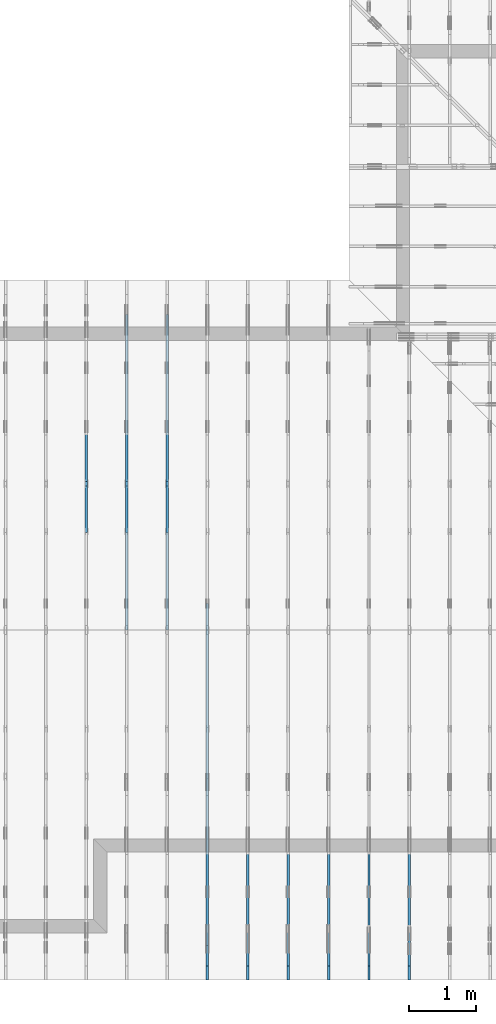
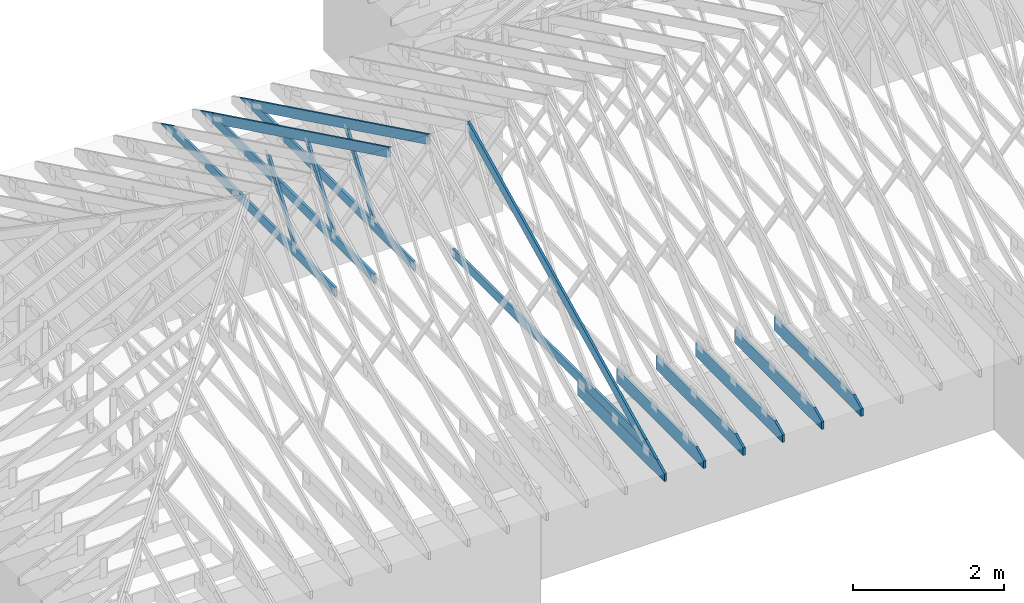
# One storey, part 11 of 159: 16 members, 9 elements without a shape of their own.
"""IFC2X3 building model written with IfcOpenShell, lengths in millimetres."""

from ifc_helpers import new_model, si_unit, frame, origin, origin_with_axes, origin_2d, place, context, project, spatial, faceted_brep, element, aggregate, save


model = new_model("IFC2X3")

# Units and contexts
model_context = context("Model", 3, precision=1e-05, world=origin())
plan_context = context("Plan", 2, precision=1e-05, world=origin_2d())
ifc_project = project(units=[si_unit("LENGTHUNIT", "METRE", prefix="MILLI"), si_unit("AREAUNIT", "SQUARE_METRE"), si_unit("VOLUMEUNIT", "CUBIC_METRE"), si_unit("SOLIDANGLEUNIT", "STERADIAN"), si_unit("PLANEANGLEUNIT", "RADIAN"), si_unit("MASSUNIT", "GRAM"), si_unit("TIMEUNIT", "SECOND"), si_unit("THERMODYNAMICTEMPERATUREUNIT", "DEGREE_CELSIUS"), si_unit("LUMINOUSINTENSITYUNIT", "LUMEN")], contexts=[model_context, plan_context])

# Site, building, storey
site_placement = place(None, origin_with_axes())
site = spatial("IfcSite", under=ifc_project, at=site_placement, CompositionType="ELEMENT")
building_placement = place(site_placement, origin_with_axes())
building = spatial("IfcBuilding", under=site, at=building_placement, Name="Plan 1", CompositionType="ELEMENT")
storey_placement = place(building_placement, origin_with_axes())
storey = spatial("IfcBuildingStorey", under=building, at=storey_placement, Name="Etasje 1", CompositionType="ELEMENT", Elevation=0.0)

# Assembly, member
assembly_1_placement = place(storey_placement, frame((10875.02226140475, -699.9989301294845, 1.1021457184401395e-15), z_axis=(-1.0, 1.836909530733566e-16, 6.123031769111886e-17), x_axis=(-1.836909530733566e-16, -1.0, 0.0)))
assembly_1 = element("IfcElementAssembly", 1, at=assembly_1_placement, inside=storey, Name="T4 (96)", AssemblyPlace="FACTORY", PredefinedType="TRUSS")
member_1_placement = place(assembly_1_placement, frame((-2299.9990234375, 0.0, -36.0), z_axis=(0.0, 0.0, 1.0), x_axis=(1.0, 0.0, 0.0)))
member_1 = element("IfcMember", 2, at=member_1_placement, Name="T4-U14", context=model_context, shape_type="Brep", body=[
    faceted_brep([(2088.8177337646484, 223.0, 36.0), (0.0, 223.0, 36.0), (0.0, 0.0, 36.0), (2300.0000933080446, 0.0, 36.0), (2300.0000933080446, 119.99948120117188, 36.0), (0.0, 223.0, 0.0), (2088.8177337646484, 223.0, 2.5579794687450473e-13), (2300.0000933080446, 119.99948120117188, 2.816594728057092e-13), (2300.0000933080446, 0.0, 2.816594728057092e-13), (0.0, 0.0, 0.0), (2088.8177277548316, 223.00000000000023, 2.524354896707238e-29), (2088.8177277548316, 223.00000000000023, 36.0), (2300.0000933080146, 119.99947818928456, 36.0), (2300.0000933080146, 119.99947818928456, 2.524354896707238e-29), (9.330801458418136e-05, 223.0, 0.0), (9.330801458418136e-05, 223.0, 36.0), (2088.817727754831, 222.99999999999986, 36.0), (2088.817727754831, 222.99999999999986, -7.888609052210118e-30), (9.330801458418136e-05, 0.0, 0.0), (9.330801458638566e-05, -2.6993892992798474e-31, 36.0), (9.330801461369438e-05, 223.0, 36.0), (9.330801461149009e-05, 223.0, -1.6721217180559947e-30), (2300.0000933080146, -4.2248920920855827e-13, 2.5869148500909603e-29), (2300.0000933080146, -4.20284917771678e-13, 36.0), (9.330801458418136e-05, 2.204274297042151e-15, 36.0), (9.330801458418136e-05, -1.713983812835093e-20, 1.0494777337732796e-36), (2300.0000933080146, 119.99947818928416, 0.0), (2300.0000933080146, 119.99947818928416, 36.0), (2300.0000933080146, 0.0, 36.0), (2300.0000933080146, 0.0, 0.0)], [[[0, 1, 2, 3, 4]], [[5, 6, 7, 8, 9]], [[10, 11, 12, 13]], [[14, 15, 16, 17]], [[18, 19, 20, 21]], [[22, 23, 24, 25]], [[26, 27, 28, 29]]]),
])
aggregate(assembly_1, [member_1])

assembly_2_placement = place(storey_placement, frame((10275.02226140475, -699.9989301294845, 1.1021457184401395e-15), z_axis=(-1.0, 1.836909530733566e-16, 6.123031769111886e-17), x_axis=(-1.836909530733566e-16, -1.0, 0.0)))
assembly_2 = element("IfcElementAssembly", 3, at=assembly_2_placement, inside=storey, Name="T3 (95)", AssemblyPlace="FACTORY", PredefinedType="TRUSS")
member_2_placement = place(assembly_2_placement, frame((-2300.000000000002, 0.0, -36.0), z_axis=(0.0, 0.0, 1.0), x_axis=(1.0, 0.0, 0.0)))
member_2 = element("IfcMember", 4, at=member_2_placement, Name="T3-U14", context=model_context, shape_type="Brep", body=[
    faceted_brep([(2088.8187103271503, 223.0, 36.0), (1.8189894035458565e-12, 223.0, 36.0), (1.8189894035458565e-12, 0.0, 36.0), (2300.0, 0.0, 36.0), (2299.9999712377066, 120.00001525878906, 36.0), (1.8189894035458565e-12, 223.0, 2.227545981117832e-28), (2088.8187103271503, 223.0, 2.5579806646496917e-13), (2299.9999712377066, 120.00001525878906, 2.81659457856898e-13), (2300.0, 0.0, 2.8165946137914677e-13), (1.8189894035458565e-12, 0.0, 2.227545981117832e-28), (2088.8187043173352, 223.0000000000001, 1.262177448353619e-29), (2088.8187043173352, 223.0000000000001, 36.0), (2299.999971237707, 120.00001402830935, 36.0), (2299.999971237707, 120.00001402830935, 1.262177448353619e-29), (0.0, 223.0, 0.0), (-1.3496946496399237e-31, 223.0, 36.0), (2088.818704317335, 222.99999999999986, 36.0), (2088.818704317335, 222.99999999999986, -7.888609052210118e-30), (0.0, 0.0, 0.0), (2.204291436880279e-15, -2.6993892992798474e-31, 36.0), (2.951301312711929e-14, 223.0, 36.0), (2.7308721690239013e-14, 223.0, -1.6721217048316832e-30), (2300.0, -4.2248919206872015e-13, 2.586914745143187e-29), (2300.0, -4.202849006318399e-13, 36.0), (4.049083948919771e-31, 2.204291436880279e-15, 36.0), (0.0, 0.0, 0.0), (2299.999999999868, 120.00001402830925, 1.7611162946620003e-21), (2299.999999999868, 120.00001402830925, 36.0), (2299.999999999868, 0.0, 36.0), (2299.999999999868, 0.0, -8.077935669463161e-27)], [[[0, 1, 2, 3, 4]], [[5, 6, 7, 8, 9]], [[10, 11, 12, 13]], [[14, 15, 16, 17]], [[18, 19, 20, 21]], [[22, 23, 24, 25]], [[26, 27, 28, 29]]]),
])
aggregate(assembly_2, [member_2])

assembly_3_placement = place(storey_placement, frame((9675.022261404752, 9699.99999999999, 1.1021457184401395e-15), z_axis=(-1.0, 1.836909530733566e-16, 6.123031769111886e-17), x_axis=(-1.836909530733566e-16, -1.0, 0.0)))
assembly_3 = element("IfcElementAssembly", 5, at=assembly_3_placement, inside=storey, Name="T2 (94)", AssemblyPlace="FACTORY", PredefinedType="TRUSS")
member_3_placement = place(assembly_3_placement, frame((8099.998930129474, 0.0, -36.0), z_axis=(0.0, 0.0, 1.0), x_axis=(1.0, 0.0, 0.0)))
member_3 = element("IfcMember", 6, at=member_3_placement, Name="T2-U14", context=model_context, shape_type="Brep", body=[
    faceted_brep([(2088.8184526830264, 223.0, 36.0), (9.330802640761249e-05, 223.0, 36.0), (9.330802640761249e-05, 0.0, 36.0), (2300.0000933080264, 0.0, 36.0), (2300.0000933080264, 120.00001525878906, 36.0), (9.330802640761249e-05, 223.0, 1.1426560200138842e-20), (2088.8184526830264, 223.0, 2.557980349137061e-13), (2300.0000933080264, 120.00001525878906, 2.8165947280570696e-13), (2300.0000933080264, 0.0, 2.8165947280570696e-13), (9.330802640761249e-05, 0.0, 1.1426560200138842e-20), (2088.8187043173357, 223.00000000000034, 2.524354896707238e-29), (2088.8187043173357, 223.00000000000034, 36.0), (2299.999971237707, 120.00001402830958, 36.0), (2299.999971237707, 120.00001402830958, 2.524354896707238e-29), (0.0, 223.0, 0.0), (-1.3496946496399237e-31, 223.0, 36.0), (2088.818704317335, 222.99999999999986, 36.0), (2088.818704317335, 222.99999999999986, -7.888609052210118e-30), (0.0, 0.0, 0.0), (2.204291436880279e-15, -2.6993892992798474e-31, 36.0), (2.951301312711929e-14, 223.0, 36.0), (2.7308721690239013e-14, 223.0, -1.6721217048316832e-30), (2300.0, -4.2248919206872015e-13, 2.586914745143187e-29), (2300.0, -4.202849006318399e-13, 36.0), (4.049083948919771e-31, 2.204291436880279e-15, 36.0), (0.0, 0.0, 0.0), (2299.999999999868, 120.00001402830924, 1.7611162946620003e-21), (2299.999999999868, 120.00001402830924, 36.0), (2299.999999999868, 0.0, 36.0), (2299.999999999868, 0.0, -8.077935669463161e-27)], [[[0, 1, 2, 3, 4]], [[5, 6, 7, 8, 9]], [[10, 11, 12, 13]], [[14, 15, 16, 17]], [[18, 19, 20, 21]], [[22, 23, 24, 25]], [[26, 27, 28, 29]]]),
])
aggregate(assembly_3, [member_3])

assembly_4_placement = place(storey_placement, frame((9075.022261404752, 9699.99999999999, 1.1021457184401395e-15), z_axis=(-1.0, 1.836909530733566e-16, 6.123031769111886e-17), x_axis=(-1.836909530733566e-16, -1.0, 0.0)))
assembly_4 = element("IfcElementAssembly", 7, at=assembly_4_placement, inside=storey, Name="T2 (93)", AssemblyPlace="FACTORY", PredefinedType="TRUSS")
member_4_placement = place(assembly_4_placement, frame((8099.998930129474, 0.0, -36.0), z_axis=(0.0, 0.0, 1.0), x_axis=(1.0, 0.0, 0.0)))
member_4 = element("IfcMember", 8, at=member_4_placement, Name="T2-U14", context=model_context, shape_type="Brep", body=[
    faceted_brep([(2088.8184526830264, 223.0, 36.0), (9.330802640761249e-05, 223.0, 36.0), (9.330802640761249e-05, 0.0, 36.0), (2300.0000933080264, 0.0, 36.0), (2300.0000933080264, 120.00001525878906, 36.0), (9.330802640761249e-05, 223.0, 1.1426560200138842e-20), (2088.8184526830264, 223.0, 2.557980349137061e-13), (2300.0000933080264, 120.00001525878906, 2.8165947280570696e-13), (2300.0000933080264, 0.0, 2.8165947280570696e-13), (9.330802640761249e-05, 0.0, 1.1426560200138842e-20), (2088.8187043173357, 223.00000000000034, 2.524354896707238e-29), (2088.8187043173357, 223.00000000000034, 36.0), (2299.999971237707, 120.00001402830958, 36.0), (2299.999971237707, 120.00001402830958, 2.524354896707238e-29), (0.0, 223.0, 0.0), (-1.3496946496399237e-31, 223.0, 36.0), (2088.818704317335, 222.99999999999986, 36.0), (2088.818704317335, 222.99999999999986, -7.888609052210118e-30), (0.0, 0.0, 0.0), (2.204291436880279e-15, -2.6993892992798474e-31, 36.0), (2.951301312711929e-14, 223.0, 36.0), (2.7308721690239013e-14, 223.0, -1.6721217048316832e-30), (2300.0, -4.2248919206872015e-13, 2.586914745143187e-29), (2300.0, -4.202849006318399e-13, 36.0), (4.049083948919771e-31, 2.204291436880279e-15, 36.0), (0.0, 0.0, 0.0), (2299.999999999868, 120.00001402830924, 1.7611162946620003e-21), (2299.999999999868, 120.00001402830924, 36.0), (2299.999999999868, 0.0, 36.0), (2299.999999999868, 0.0, -8.077935669463161e-27)], [[[0, 1, 2, 3, 4]], [[5, 6, 7, 8, 9]], [[10, 11, 12, 13]], [[14, 15, 16, 17]], [[18, 19, 20, 21]], [[22, 23, 24, 25]], [[26, 27, 28, 29]]]),
])
aggregate(assembly_4, [member_4])

assembly_5_placement = place(storey_placement, frame((8475.022261404752, 9699.99999999999, 1.1021457184401395e-15), z_axis=(-1.0, 1.836909530733566e-16, 6.123031769111886e-17), x_axis=(-1.836909530733566e-16, -1.0, 0.0)))
assembly_5 = element("IfcElementAssembly", 9, at=assembly_5_placement, inside=storey, Name="T2 (92)", AssemblyPlace="FACTORY", PredefinedType="TRUSS")
member_5_placement = place(assembly_5_placement, frame((8099.998930129474, 0.0, -36.0), z_axis=(0.0, 0.0, 1.0), x_axis=(1.0, 0.0, 0.0)))
member_5 = element("IfcMember", 10, at=member_5_placement, Name="T2-U14", context=model_context, shape_type="Brep", body=[
    faceted_brep([(2088.8184526830264, 223.0, 36.0), (9.330802640761249e-05, 223.0, 36.0), (9.330802640761249e-05, 0.0, 36.0), (2300.0000933080264, 0.0, 36.0), (2300.0000933080264, 120.00001525878906, 36.0), (9.330802640761249e-05, 223.0, 1.1426560200138842e-20), (2088.8184526830264, 223.0, 2.557980349137061e-13), (2300.0000933080264, 120.00001525878906, 2.8165947280570696e-13), (2300.0000933080264, 0.0, 2.8165947280570696e-13), (9.330802640761249e-05, 0.0, 1.1426560200138842e-20), (2088.8187043173357, 223.00000000000034, 2.524354896707238e-29), (2088.8187043173357, 223.00000000000034, 36.0), (2299.999971237707, 120.00001402830958, 36.0), (2299.999971237707, 120.00001402830958, 2.524354896707238e-29), (0.0, 223.0, 0.0), (-1.3496946496399237e-31, 223.0, 36.0), (2088.818704317335, 222.99999999999986, 36.0), (2088.818704317335, 222.99999999999986, -7.888609052210118e-30), (0.0, 0.0, 0.0), (2.204291436880279e-15, -2.6993892992798474e-31, 36.0), (2.951301312711929e-14, 223.0, 36.0), (2.7308721690239013e-14, 223.0, -1.6721217048316832e-30), (2300.0, -4.2248919206872015e-13, 2.586914745143187e-29), (2300.0, -4.202849006318399e-13, 36.0), (4.049083948919771e-31, 2.204291436880279e-15, 36.0), (0.0, 0.0, 0.0), (2299.999999999868, 120.00001402830924, 1.7611162946620003e-21), (2299.999999999868, 120.00001402830924, 36.0), (2299.999999999868, 0.0, 36.0), (2299.999999999868, 0.0, -8.077935669463161e-27)], [[[0, 1, 2, 3, 4]], [[5, 6, 7, 8, 9]], [[10, 11, 12, 13]], [[14, 15, 16, 17]], [[18, 19, 20, 21]], [[22, 23, 24, 25]], [[26, 27, 28, 29]]]),
])
aggregate(assembly_5, [member_5])

# Assembly, members
assembly_6_placement = place(storey_placement, frame((7875.0222614047525, 9699.99999999999, 1.1021457184401395e-15), z_axis=(-1.0, 1.836909530733566e-16, 6.123031769111886e-17), x_axis=(-1.836909530733566e-16, -1.0, 0.0)))
assembly_6 = element("IfcElementAssembly", 11, at=assembly_6_placement, inside=storey, Name="T2 (91)", AssemblyPlace="FACTORY", PredefinedType="TRUSS")
member_6_placement = place(assembly_6_placement, frame((5135.120455399391, 2523.187516882459, -36.0), z_axis=(0.0, 0.0, 1.0), x_axis=(0.8987940462991668, -0.4383711467890778, 0.0)))
member_6 = element("IfcMember", 12, at=member_6_placement, Name="T2-O3", context=model_context, shape_type="Brep", body=[
    faceted_brep([(5212.955657516367, 148.00034936960947, 36.0), (2.9272871415741974e-05, 148.00034936960947, 36.0), (72.18443128276795, 0.00027202273031434743, 36.0), (4909.50997264878, 0.00027202273031434743, 36.0), (2.9272871415741974e-05, 148.00034936960947, 3.584774433034307e-21), (5212.955657516367, 148.00034936960947, 6.383818620388851e-13), (4909.50997264878, 0.00027202273031434743, 6.012217106660022e-13), (72.18443128276795, 0.00027202273031434743, 8.83975131959324e-15), (72.18442310739601, 0.00018235889274720307, -7.888609052210118e-31), (72.18442310739601, 0.00018235889274720307, 36.0), (2.842170943040401e-14, 148.00018235817151, 36.0), (2.842170943040401e-14, 148.00018235817151, -2.3665827156630354e-30), (4909.510346538232, 0.0001823580668906902, 2.246999438374223e-28), (4909.510346538232, 0.0001823580668928945, 36.0), (72.18442310739601, 0.00018235889269189838, 36.0), (72.18442310739601, 0.0001823588926896941, 3.303759786827862e-30), (5212.955315092269, 148.00018235821926, -2.524354896707238e-29), (5212.955315092269, 148.00018235821926, 36.0), (4909.51034653823, 0.00018235807056043996, 36.0), (4909.51034653823, 0.00018235807056043996, -2.524354896707238e-29), (0.0, 148.00018235817151, 0.0), (0.0, 148.00018235817151, 36.0), (5212.95531509227, 148.00018235821864, 36.0), (5212.95531509227, 148.00018235821867, -1.1044052673094165e-29)], [[[0, 1, 2, 3]], [[4, 5, 6, 7]], [[8, 9, 10, 11]], [[12, 13, 14, 15]], [[16, 17, 18, 19]], [[20, 21, 22, 23]]]),
])
member_7_placement = place(assembly_6_placement, frame((8099.998930129474, 0.0, -36.0), z_axis=(0.0, 0.0, 1.0), x_axis=(1.0, 0.0, 0.0)))
member_7 = element("IfcMember", 13, at=member_7_placement, Name="T2-U14", context=model_context, shape_type="Brep", body=[
    faceted_brep([(2088.8184526830264, 223.0, 36.0), (9.330802640761249e-05, 223.0, 36.0), (9.330802640761249e-05, 0.0, 36.0), (2300.0000933080264, 0.0, 36.0), (2300.0000933080264, 120.00001525878906, 36.0), (9.330802640761249e-05, 223.0, 1.1426560200138842e-20), (2088.8184526830264, 223.0, 2.557980349137061e-13), (2300.0000933080264, 120.00001525878906, 2.8165947280570696e-13), (2300.0000933080264, 0.0, 2.8165947280570696e-13), (9.330802640761249e-05, 0.0, 1.1426560200138842e-20), (2088.8187043173357, 223.00000000000034, 2.524354896707238e-29), (2088.8187043173357, 223.00000000000034, 36.0), (2299.999971237707, 120.00001402830958, 36.0), (2299.999971237707, 120.00001402830958, 2.524354896707238e-29), (0.0, 223.0, 0.0), (-1.3496946496399237e-31, 223.0, 36.0), (2088.818704317335, 222.99999999999986, 36.0), (2088.818704317335, 222.99999999999986, -7.888609052210118e-30), (0.0, 0.0, 0.0), (2.204291436880279e-15, -2.6993892992798474e-31, 36.0), (2.951301312711929e-14, 223.0, 36.0), (2.7308721690239013e-14, 223.0, -1.6721217048316832e-30), (2300.0, -4.2248919206872015e-13, 2.586914745143187e-29), (2300.0, -4.202849006318399e-13, 36.0), (4.049083948919771e-31, 2.204291436880279e-15, 36.0), (0.0, 0.0, 0.0), (2299.999999999868, 120.00001402830924, 1.7611162946620003e-21), (2299.999999999868, 120.00001402830924, 36.0), (2299.999999999868, 0.0, 36.0), (2299.999999999868, 0.0, -8.077935669463161e-27)], [[[0, 1, 2, 3, 4]], [[5, 6, 7, 8, 9]], [[10, 11, 12, 13]], [[14, 15, 16, 17]], [[18, 19, 20, 21]], [[22, 23, 24, 25]], [[26, 27, 28, 29]]]),
])
member_8_placement = place(assembly_6_placement, frame((10188.817634446803, 370.99999999999994, -36.0), z_axis=(0.0, 0.0, 1.0), x_axis=(-1.0, 1.2246063538223773e-16, 0.0)))
member_8 = element("IfcMember", 14, at=member_8_placement, Name="T2-U32", context=model_context, shape_type="Brep", body=[
    faceted_brep([(5379.999763353053, 148.0000000000006, 36.0), (0.00025163430291286204, 148.0000000000006, 36.0), (303.4445875718029, 0.0, 36.0), (5379.999763353053, 0.0, 36.0), (0.00025163430291286204, 148.0000000000006, 3.081529661867556e-20), (5379.999763353053, 148.0000000000006, 6.588381893765035e-13), (5379.999763353053, 0.0, 6.588381893765035e-13), (303.4445875718029, 0.0, 3.716001699734406e-14), (303.4449685537348, 1.2789769243681803e-13, -3.99587178143416e-30), (303.4449685537348, 1.2789769243681803e-13, 36.0), (7.105427357601002e-15, 148.00000000000009, 36.0), (7.105427357601002e-15, 148.00000000000009, -2.9555199832572376e-30), (5380.0, -8.745704898130424e-13, 6.051131012552325e-29), (5380.0, -8.723661983761621e-13, 36.0), (303.4449685537347, 6.015103367954605e-14, 36.0), (303.4449685537347, 5.794674224266577e-14, 3.4129837543094226e-30), (5380.0, 148.00000000000006, 0.0), (5380.0, 148.00000000000006, 36.0), (5380.0, 1.1368683772161603e-13, 36.0), (5380.0, 1.1368683772161603e-13, 0.0), (0.0, 148.00000000000006, 0.0), (-1.3496946496399237e-31, 148.00000000000006, 36.0), (5380.0, 147.99999999999972, 36.0), (5380.0, 147.99999999999972, -2.0510383535746307e-29)], [[[0, 1, 2, 3]], [[4, 5, 6, 7]], [[8, 9, 10, 11]], [[12, 13, 14, 15]], [[16, 17, 18, 19]], [[20, 21, 22, 23]]]),
])
aggregate(assembly_6, [member_6, member_7, member_8])

assembly_7_placement = place(storey_placement, frame((7275.0222614047525, 9699.99999999999, 1.1021457184401395e-15), z_axis=(-1.0, 1.836909530733566e-16, 6.123031769111886e-17), x_axis=(-1.836909530733566e-16, -1.0, 0.0)))
assembly_7 = element("IfcElementAssembly", 15, at=assembly_7_placement, inside=storey, Name="T2 (90)", AssemblyPlace="FACTORY", PredefinedType="TRUSS")
member_9_placement = place(assembly_7_placement, frame((579.5051980003889, 237.97847286708455, -36.00000000000001), z_axis=(0.0, 0.0, 1.0), x_axis=(0.8987940462991671, 0.43837114678907757, 0.0)))
member_9 = element("IfcMember", 16, at=member_9_placement, Name="T2-O3", context=model_context, shape_type="Brep", body=[
    faceted_brep([(5212.955369683486, 148.00001471731446, 36.0), (1.573016606926103e-05, 148.00001471731446, 36.0), (303.44498744329735, 0.0, 36.0), (5140.770967673589, 0.0, 36.0), (1.573016606926103e-05, 148.00001471731446, 1.9263261315098228e-21), (5212.955369683486, 148.00001471731446, 6.383818267906877e-13), (5140.770967673589, 0.0, 6.295420790558688e-13), (303.44498744329735, 0.0, 3.716006596586134e-14), (303.44496855236554, 9.213724169399029e-06, 8.404281481000962e-31), (303.44496855236554, 9.213724169399029e-06, 36.0), (0.0, 148.000009213056, 36.0), (0.0, 148.000009213056, -1.9992365007213114e-31), (5140.770891984262, 9.214032787493993e-06, -1.5668329852774188e-28), (5140.770891984262, 9.214032789698284e-06, 36.0), (303.4449685523656, 9.213724336859708e-06, 36.0), (303.4449685523656, 9.213724334655416e-06, -9.24856583218491e-30), (5212.955315091657, 148.00000921330889, -5.793884668474286e-29), (5212.955315091657, 148.00000921330889, 36.0), (5140.770891984262, 9.214030342263868e-06, 36.0), (5140.770891984262, 9.214030342263868e-06, -5.743143320920135e-29), (0.0, 148.000009213056, 0.0), (0.0, 148.000009213056, 36.0), (5212.955315091657, 148.00000921330917, 36.0), (5212.955315091657, 148.00000921330917, 9.466330862652142e-30)], [[[0, 1, 2, 3]], [[4, 5, 6, 7]], [[8, 9, 10, 11]], [[12, 13, 14, 15]], [[16, 17, 18, 19]], [[20, 21, 22, 23]]]),
])
member_10_placement = place(assembly_7_placement, frame((4808.81787109375, 371.0000000000005, -36.0), z_axis=(0.0, 0.0, 1.0), x_axis=(-1.0, 1.2246063538223773e-16, 0.0)))
member_10 = element("IfcMember", 17, at=member_10_placement, Name="T2-U35", context=model_context, shape_type="Brep", body=[
    faceted_brep([(4597.636581420898, 148.00000000000105, 36.0), (0.0, 148.00000000000105, 36.0), (0.0, 5.115907697472721e-13, 36.0), (4294.191589355469, 5.115907697472721e-13, 36.0), (0.0, 148.00000000000105, 0.0), (4597.636581420898, 148.00000000000105, 5.630294970174226e-13), (4294.191589355469, 5.115907697472721e-13, 5.25869430485532e-13), (0.0, 5.115907697472721e-13, 0.0), (0.00023664694708713796, 0.0, 0.0), (0.00023664694708934225, -2.6993892992798474e-31, 36.0), (0.00023664694710746643, 147.99999999999994, 36.0), (0.00023664694710526213, 147.99999999999994, -1.1097479173457682e-30), (4294.191606856883, -7.888042053292689e-13, 1.1094846280734072e-28), (4294.191606856883, -7.865999138923886e-13, 36.0), (0.00023664694708713796, 2.2041915808575547e-15, 36.0), (0.00023664694708713796, -9.985602272457245e-20, 6.114215994797155e-36), (4597.636575412006, 148.00000000000205, -2.5243548967072372e-29), (4597.636575412006, 148.00000000000205, 36.0), (4294.191606856883, 1.5916157281026244e-12, 36.0), (4294.191606856883, 1.5916157281026244e-12, -2.5243548967072372e-29), (0.00023664694708713796, 147.99999999999994, 0.0), (0.00023664694708713796, 147.99999999999994, 36.0), (4597.636575412005, 148.00000000000068, 36.0), (4597.636575412005, 148.00000000000068, -2.208810534618833e-29)], [[[0, 1, 2, 3]], [[4, 5, 6, 7]], [[8, 9, 10, 11]], [[12, 13, 14, 15]], [[16, 17, 18, 19]], [[20, 21, 22, 23]]]),
])
member_11_placement = place(assembly_7_placement, frame((2992.962039007774, 1415.1000197155186, -36.0), z_axis=(0.0, 0.0, 1.0), x_axis=(0.5642475050068997, -0.8256056886271368, 0.0)))
member_11 = element("IfcMember", 18, at=member_11_placement, Name="T2-D42", context=model_context, shape_type="Brep", body=[
    faceted_brep([(1236.1860950310158, 73.0001983605489, 36.0), (10.714657585100667, 73.0001983605489, 36.0), (2.9073682981106685e-06, 0.00014238622361517628, 36.0), (1264.647317839714, 0.00014238622361517628, 36.0), (10.714657585100667, 73.0001983605489, 1.3121237757745405e-15), (1236.1860950310158, 73.0001983605489, 1.513841346481855e-13), (1264.647317839714, 0.00014238622361517628, 1.5486951407709413e-13), (2.9073682981106685e-06, 0.00014238622361517628, 3.560381690768076e-22), (-1.0876495965808294e-15, 9.815680186891362e-05, 6.73106873190455e-32), (1.0932755894164925e-15, 9.815680186859351e-05, 36.0), (10.71468588481117, 73.00009815680141, 36.0), (10.714685884811168, 73.00009815680141, -5.004528960490232e-31), (1264.6473849234712, 9.81568027596822e-05, 5.682548008281813e-29), (1264.6473849234712, 9.815680276188649e-05, 36.0), (-1.5529013882837331e-30, 9.815680187095826e-05, 36.0), (0.0, 9.815680186875397e-05, 0.0), (1236.1860298813824, 73.00009815680414, 0.0), (1236.1860298813824, 73.00009815680414, 36.0), (1264.6473849234712, 9.81568037445868e-05, 36.0), (1264.6473849234712, 9.81568037445868e-05, 1.262177448353619e-29), (10.714685884811162, 73.00009815680141, 0.0), (10.714685884811162, 73.0000981568014, 36.0), (1236.1860298813824, 73.00009815680406, 36.0), (1236.1860298813824, 73.00009815680406, -5.5220263365470826e-30)], [[[0, 1, 2, 3]], [[4, 5, 6, 7]], [[8, 9, 10, 11]], [[12, 13, 14, 15]], [[16, 17, 18, 19]], [[20, 21, 22, 23]]]),
])
aggregate(assembly_7, [member_9, member_10, member_11])

assembly_8_placement = place(storey_placement, frame((6675.0222614047525, 9699.99999999999, 1.1021457184401395e-15), z_axis=(-1.0, 1.836909530733566e-16, 6.123031769111886e-17), x_axis=(-1.836909530733566e-16, -1.0, 0.0)))
assembly_8 = element("IfcElementAssembly", 19, at=assembly_8_placement, inside=storey, Name="T2 (89)", AssemblyPlace="FACTORY", PredefinedType="TRUSS")
member_12_placement = place(assembly_8_placement, frame((579.5051980003889, 237.97847286708455, -36.00000000000001), z_axis=(0.0, 0.0, 1.0), x_axis=(0.8987940462991671, 0.43837114678907757, 0.0)))
member_12 = element("IfcMember", 20, at=member_12_placement, Name="T2-O3", context=model_context, shape_type="Brep", body=[
    faceted_brep([(5212.955369683486, 148.00001471731446, 36.0), (1.573016606926103e-05, 148.00001471731446, 36.0), (303.44498744329735, 0.0, 36.0), (5140.770967673589, 0.0, 36.0), (1.573016606926103e-05, 148.00001471731446, 1.9263261315098228e-21), (5212.955369683486, 148.00001471731446, 6.383818267906877e-13), (5140.770967673589, 0.0, 6.295420790558688e-13), (303.44498744329735, 0.0, 3.716006596586134e-14), (303.44496855236554, 9.213724169399029e-06, 8.404281481000962e-31), (303.44496855236554, 9.213724169399029e-06, 36.0), (0.0, 148.000009213056, 36.0), (0.0, 148.000009213056, -1.9992365007213114e-31), (5140.770891984262, 9.214032787493993e-06, -1.5668329852774188e-28), (5140.770891984262, 9.214032789698284e-06, 36.0), (303.4449685523656, 9.213724336859708e-06, 36.0), (303.4449685523656, 9.213724334655416e-06, -9.24856583218491e-30), (5212.955315091657, 148.00000921330889, -5.793884668474286e-29), (5212.955315091657, 148.00000921330889, 36.0), (5140.770891984262, 9.214030342263868e-06, 36.0), (5140.770891984262, 9.214030342263868e-06, -5.743143320920135e-29), (0.0, 148.000009213056, 0.0), (0.0, 148.000009213056, 36.0), (5212.955315091657, 148.00000921330917, 36.0), (5212.955315091657, 148.00000921330917, 9.466330862652142e-30)], [[[0, 1, 2, 3]], [[4, 5, 6, 7]], [[8, 9, 10, 11]], [[12, 13, 14, 15]], [[16, 17, 18, 19]], [[20, 21, 22, 23]]]),
])
member_13_placement = place(assembly_8_placement, frame((4808.81787109375, 371.0000000000005, -36.0), z_axis=(0.0, 0.0, 1.0), x_axis=(-1.0, 1.2246063538223773e-16, 0.0)))
member_13 = element("IfcMember", 21, at=member_13_placement, Name="T2-U35", context=model_context, shape_type="Brep", body=[
    faceted_brep([(4597.636581420898, 148.00000000000105, 36.0), (0.0, 148.00000000000105, 36.0), (0.0, 5.115907697472721e-13, 36.0), (4294.191589355469, 5.115907697472721e-13, 36.0), (0.0, 148.00000000000105, 0.0), (4597.636581420898, 148.00000000000105, 5.630294970174226e-13), (4294.191589355469, 5.115907697472721e-13, 5.25869430485532e-13), (0.0, 5.115907697472721e-13, 0.0), (0.00023664694708713796, 0.0, 0.0), (0.00023664694708934225, -2.6993892992798474e-31, 36.0), (0.00023664694710746643, 147.99999999999994, 36.0), (0.00023664694710526213, 147.99999999999994, -1.1097479173457682e-30), (4294.191606856883, -7.888042053292689e-13, 1.1094846280734072e-28), (4294.191606856883, -7.865999138923886e-13, 36.0), (0.00023664694708713796, 2.2041915808575547e-15, 36.0), (0.00023664694708713796, -9.985602272457245e-20, 6.114215994797155e-36), (4597.636575412006, 148.00000000000205, -2.5243548967072372e-29), (4597.636575412006, 148.00000000000205, 36.0), (4294.191606856883, 1.5916157281026244e-12, 36.0), (4294.191606856883, 1.5916157281026244e-12, -2.5243548967072372e-29), (0.00023664694708713796, 147.99999999999994, 0.0), (0.00023664694708713796, 147.99999999999994, 36.0), (4597.636575412005, 148.00000000000068, 36.0), (4597.636575412005, 148.00000000000068, -2.208810534618833e-29)], [[[0, 1, 2, 3]], [[4, 5, 6, 7]], [[8, 9, 10, 11]], [[12, 13, 14, 15]], [[16, 17, 18, 19]], [[20, 21, 22, 23]]]),
])
member_14_placement = place(assembly_8_placement, frame((2992.962039007774, 1415.1000197155186, -36.0), z_axis=(0.0, 0.0, 1.0), x_axis=(0.5642475050068997, -0.8256056886271368, 0.0)))
member_14 = element("IfcMember", 22, at=member_14_placement, Name="T2-D42", context=model_context, shape_type="Brep", body=[
    faceted_brep([(1236.1860950310158, 73.0001983605489, 36.0), (10.714657585100667, 73.0001983605489, 36.0), (2.9073682981106685e-06, 0.00014238622361517628, 36.0), (1264.647317839714, 0.00014238622361517628, 36.0), (10.714657585100667, 73.0001983605489, 1.3121237757745405e-15), (1236.1860950310158, 73.0001983605489, 1.513841346481855e-13), (1264.647317839714, 0.00014238622361517628, 1.5486951407709413e-13), (2.9073682981106685e-06, 0.00014238622361517628, 3.560381690768076e-22), (-1.0876495965808294e-15, 9.815680186891362e-05, 6.73106873190455e-32), (1.0932755894164925e-15, 9.815680186859351e-05, 36.0), (10.71468588481117, 73.00009815680141, 36.0), (10.714685884811168, 73.00009815680141, -5.004528960490232e-31), (1264.6473849234712, 9.81568027596822e-05, 5.682548008281813e-29), (1264.6473849234712, 9.815680276188649e-05, 36.0), (-1.5529013882837331e-30, 9.815680187095826e-05, 36.0), (0.0, 9.815680186875397e-05, 0.0), (1236.1860298813824, 73.00009815680414, 0.0), (1236.1860298813824, 73.00009815680414, 36.0), (1264.6473849234712, 9.81568037445868e-05, 36.0), (1264.6473849234712, 9.81568037445868e-05, 1.262177448353619e-29), (10.714685884811162, 73.00009815680141, 0.0), (10.714685884811162, 73.0000981568014, 36.0), (1236.1860298813824, 73.00009815680406, 36.0), (1236.1860298813824, 73.00009815680406, -5.5220263365470826e-30)], [[[0, 1, 2, 3]], [[4, 5, 6, 7]], [[8, 9, 10, 11]], [[12, 13, 14, 15]], [[16, 17, 18, 19]], [[20, 21, 22, 23]]]),
])
aggregate(assembly_8, [member_12, member_13, member_14])

assembly_9_placement = place(storey_placement, frame((6075.0222614047525, 9699.99999999999, 1.1021457184401395e-15), z_axis=(-1.0, 1.836909530733566e-16, 6.123031769111886e-17), x_axis=(-1.836909530733566e-16, -1.0, 0.0)))
assembly_9 = element("IfcElementAssembly", 23, at=assembly_9_placement, inside=storey, Name="T1 (88)", AssemblyPlace="FACTORY", PredefinedType="TRUSS")
member_15_placement = place(assembly_9_placement, frame((4808.81787109375, 371.0000000000005, -36.0), z_axis=(0.0, 0.0, 1.0), x_axis=(-1.0, 1.2246063538223773e-16, 0.0)))
member_15 = element("IfcMember", 24, at=member_15_placement, Name="T1-U35", context=model_context, shape_type="Brep", body=[
    faceted_brep([(4597.636581420898, 148.00000000000105, 36.0), (0.0, 148.00000000000105, 36.0), (0.0, 5.115907697472721e-13, 36.0), (4294.191589355469, 5.115907697472721e-13, 36.0), (0.0, 148.00000000000105, 0.0), (4597.636581420898, 148.00000000000105, 5.630294970174226e-13), (4294.191589355469, 5.115907697472721e-13, 5.25869430485532e-13), (0.0, 5.115907697472721e-13, 0.0), (0.00023664694708713796, 0.0, 0.0), (0.00023664694708934225, -2.6993892992798474e-31, 36.0), (0.00023664694710746643, 147.99999999999994, 36.0), (0.00023664694710526213, 147.99999999999994, -1.1097479173457682e-30), (4294.191606856883, -7.888042053292689e-13, 1.1094846280734072e-28), (4294.191606856883, -7.865999138923886e-13, 36.0), (0.00023664694708713796, 2.2041915808575547e-15, 36.0), (0.00023664694708713796, -9.985602272457245e-20, 6.114215994797155e-36), (4597.636575412006, 148.00000000000205, -2.5243548967072372e-29), (4597.636575412006, 148.00000000000205, 36.0), (4294.191606856883, 1.5916157281026244e-12, 36.0), (4294.191606856883, 1.5916157281026244e-12, -2.5243548967072372e-29), (0.00023664694708713796, 147.99999999999994, 0.0), (0.00023664694708713796, 147.99999999999994, 36.0), (4597.636575412005, 148.00000000000068, 36.0), (4597.636575412005, 148.00000000000068, -2.208810534618833e-29)], [[[0, 1, 2, 3]], [[4, 5, 6, 7]], [[8, 9, 10, 11]], [[12, 13, 14, 15]], [[16, 17, 18, 19]], [[20, 21, 22, 23]]]),
])
member_16_placement = place(assembly_9_placement, frame((2992.962039007774, 1415.1000197155186, -36.0), z_axis=(0.0, 0.0, 1.0), x_axis=(0.5642475050068997, -0.8256056886271368, 0.0)))
member_16 = element("IfcMember", 25, at=member_16_placement, Name="T1-D42", context=model_context, shape_type="Brep", body=[
    faceted_brep([(1236.1860950310158, 73.0001983605489, 36.0), (10.714657585100667, 73.0001983605489, 36.0), (2.9073682981106685e-06, 0.00014238622361517628, 36.0), (1264.647317839714, 0.00014238622361517628, 36.0), (10.714657585100667, 73.0001983605489, 1.3121237757745405e-15), (1236.1860950310158, 73.0001983605489, 1.513841346481855e-13), (1264.647317839714, 0.00014238622361517628, 1.5486951407709413e-13), (2.9073682981106685e-06, 0.00014238622361517628, 3.560381690768076e-22), (-1.0876495965808294e-15, 9.815680186891362e-05, 6.73106873190455e-32), (1.0932755894164925e-15, 9.815680186859351e-05, 36.0), (10.71468588481117, 73.00009815680141, 36.0), (10.714685884811168, 73.00009815680141, -5.004528960490232e-31), (1264.6473849234712, 9.81568027596822e-05, 5.682548008281813e-29), (1264.6473849234712, 9.815680276188649e-05, 36.0), (-1.5529013882837331e-30, 9.815680187095826e-05, 36.0), (0.0, 9.815680186875397e-05, 0.0), (1236.1860298813824, 73.00009815680414, 0.0), (1236.1860298813824, 73.00009815680414, 36.0), (1264.6473849234712, 9.81568037445868e-05, 36.0), (1264.6473849234712, 9.81568037445868e-05, 1.262177448353619e-29), (10.714685884811162, 73.00009815680141, 0.0), (10.714685884811162, 73.0000981568014, 36.0), (1236.1860298813824, 73.00009815680406, 36.0), (1236.1860298813824, 73.00009815680406, -5.5220263365470826e-30)], [[[0, 1, 2, 3]], [[4, 5, 6, 7]], [[8, 9, 10, 11]], [[12, 13, 14, 15]], [[16, 17, 18, 19]], [[20, 21, 22, 23]]]),
])
aggregate(assembly_9, [member_15, member_16])

save(model, "model.ifc")
